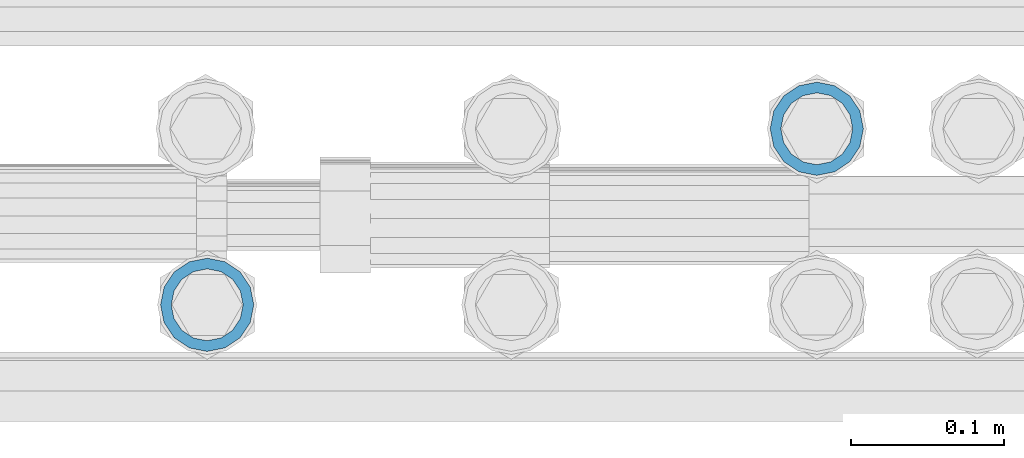
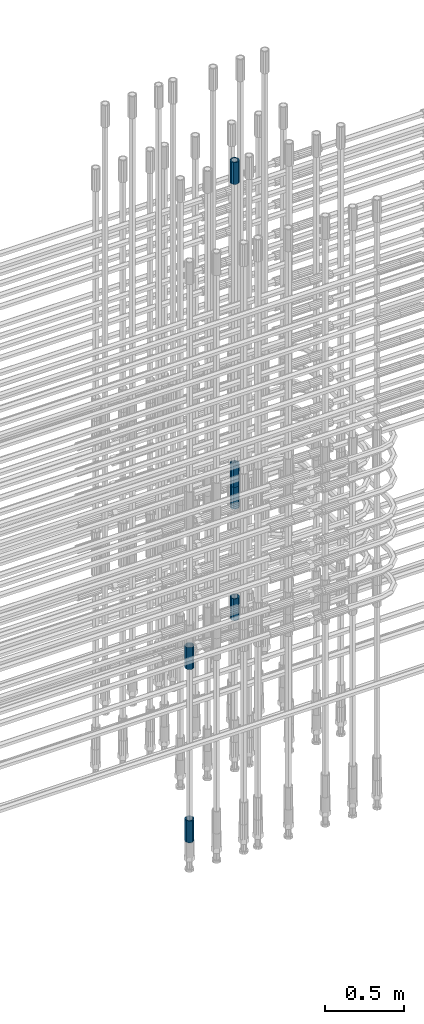
# One storey, part 19 of 119: 6 beams.
"""IFC2X3 building model written with IfcOpenShell, lengths in millimetres."""

from ifc_helpers import new_model, si_unit, frame, origin_with_axes, place, context, subcontext, project, spatial, faceted_brep, material, type_object, element, save


model = new_model("IFC2X3")

# Units and contexts
model_context = context("Model", 3, precision=1e-05, world=origin_with_axes())
body_context = subcontext(model_context, "Body", "Model", "MODEL_VIEW")
ifc_project = project(units=[si_unit("LENGTHUNIT", "METRE", prefix="MILLI"), si_unit("AREAUNIT", "SQUARE_METRE"), si_unit("VOLUMEUNIT", "CUBIC_METRE"), si_unit("MASSUNIT", "GRAM", prefix="KILO"), si_unit("TIMEUNIT", "SECOND"), si_unit("PLANEANGLEUNIT", "RADIAN"), si_unit("SOLIDANGLEUNIT", "STERADIAN"), si_unit("THERMODYNAMICTEMPERATUREUNIT", "DEGREE_CELSIUS"), si_unit("LUMINOUSINTENSITYUNIT", "LUMEN")], contexts=[model_context])

# Site, building, storey
site_placement = place(None, origin_with_axes())
site = spatial("IfcSite", under=ifc_project, at=site_placement, CompositionType="ELEMENT")
building_placement = place(site_placement, origin_with_axes())
building = spatial("IfcBuilding", under=site, at=building_placement, Name="Undefined", CompositionType="ELEMENT")
storey_placement = place(building_placement, origin_with_axes())
storey = spatial("IfcBuildingStorey", under=building, at=storey_placement, Name="Undefined", CompositionType="ELEMENT", Elevation=0.0)

# Beams
ifc_material = material(Name="STEEL/S275")
beam_type = type_object("IfcBeamType", PredefinedType="NOTDEFINED")
beam_1_placement = place(storey_placement, frame((2035525.00620663, 6205269.00125114, 20704.605729163), z_axis=(1.0, 0.0, 0.0), x_axis=(0.0, 0.0, 1.0)))
element("IfcBeam", 1, at=beam_1_placement, inside=storey, type_object=beam_type, material=ifc_material, Name="AG40N", context=body_context, shape_type="Brep", body=[
    faceted_brep([(1.62981450557709e-09, -23.4999999990687, 0.0), (7.45058059692383e-09, -21.7111690142192, 8.99306066057534), (170.000002125278, -21.711168999318, 8.99306066022245), (170.000002127141, -23.4999999844003, -3.66071617463604e-10), (4.65661287307739e-09, -16.6170093587134, 16.6170093578889), (170.000002122484, -16.6170093440451, 16.6170093575288), (1.86264514923096e-09, -8.99306066217832, 21.7111690140277), (170.000002118759, -8.99306064750999, 21.7111690136603), (2.3283064365387e-10, 9.31322574615479e-10, 23.5), (170.000002114102, 1.28056854009628e-08, 23.4999999996485), (-6.51925802230835e-09, 8.99306065868586, 21.7111690140241), (170.00000211224, 8.99306067335419, 21.7111690136639), (-7.45058059692383e-09, 16.6170093561523, 16.6170093578853), (170.000002109446, 16.6170093708206, 16.6170093575324), (-9.31322574615479e-09, 21.711169013055, 8.99306066057534), (170.000002108514, 21.7111690277234, 8.99306066022245), (-1.16415321826935e-09, 23.5000000009313, 0.0), (170.000002108514, 23.5000000144355, -3.66071617463604e-10), (-8.38190317153931e-09, 21.7111690151505, -8.99306066059444), (170.000002110377, 21.7111690300517, -8.9930606609546), (-5.58793544769287e-09, 16.6170093598776, -16.6170093579008), (170.000002113171, 16.6170093745459, -16.6170093582609), (-9.31322574615479e-10, 8.99306066334248, -21.7111690140396), (170.000002115965, 8.99306067801081, -21.7111690143961), (2.3283064365387e-10, 9.31322574615479e-10, -23.5), (170.00000211969, 1.7927959561348e-08, -23.5000000003843), (5.58793544769287e-09, -8.99306065752171, -21.7111690140396), (170.000002123415, -8.99306064285338, -21.7111690143961), (8.38190317153931e-09, -16.6170093549881, -16.6170093579008), (170.000002125278, -16.6170093403198, -16.6170093582646), (9.31322574615479e-09, -21.7111690121237, -8.99306066059444), (170.000002127141, -21.7111689972226, -8.9930606609546), (1.11758708953857e-08, -30.4999999990687, -9.54969436861575e-12), (1.30385160446167e-08, -28.1783257392235, -11.6718446871514), (170.000002129003, -28.1783257243223, -11.6718446875116), (170.000002129935, -30.4999999841675, -3.66071617463604e-10), (1.02445483207703e-08, -21.5667568228673, -21.5667568262129), (170.000002128072, -21.566756808199, -21.5667568265694), (7.45058059692383e-09, -11.6718446831219, -28.1783257416196), (170.000002125278, -11.6718446684536, -28.1783257419834), (3.72529029846191e-09, 3.95812094211578e-09, -30.5000000000277), (170.00000211969, 1.83936208486557e-08, -30.5000000003879), (-9.31322574615479e-10, 11.6718446905725, -28.1783257416232), (170.000002115965, 11.6718447052408, -28.1783257419797), (-6.51925802230835e-09, 21.5667568286881, -21.5667568262093), (170.000002110377, 21.5667568433564, -21.5667568265694), (-9.31322574615479e-09, 28.178325742716, -11.6718446871478), (170.000002108514, 28.1783257573843, -11.6718446875079), (-1.21071934700012e-08, 30.5, -5.91171556152403e-12), (170.000002106652, 30.5000000144355, -3.62433638656512e-10), (-1.21071934700012e-08, 28.1783257401548, 11.6718446871359), (170.00000210572, 28.1783257548232, 11.6718446867794), (-1.02445483207703e-08, 21.5667568240315, 21.5667568261974), (170.000002107583, 21.566756838467, 21.5667568258409), (-7.45058059692383e-09, 11.671844684286, 28.1783257416041), (170.000002110377, 11.6718446989544, 28.178325741244), (-2.79396772384644e-09, -2.56113708019257e-09, 30.5000000000159), (170.000002114102, 1.18743628263474e-08, 30.4999999996558), (1.86264514923096e-09, -11.6718446896411, 28.1783257416114), (170.000002118759, -11.67184467474, 28.178325741244), (7.45058059692383e-09, -21.5667568275239, 21.5667568261974), (170.000002123415, -21.5667568126228, 21.5667568258373), (1.02445483207703e-08, -28.1783257415518, 11.6718446871359), (170.000002127141, -28.1783257271163, 11.6718446867794)], [[[0, 1, 2, 3]], [[1, 4, 5, 2]], [[4, 6, 7, 5]], [[6, 8, 9, 7]], [[8, 10, 11, 9]], [[10, 12, 13, 11]], [[12, 14, 15, 13]], [[14, 16, 17, 15]], [[16, 18, 19, 17]], [[18, 20, 21, 19]], [[20, 22, 23, 21]], [[22, 24, 25, 23]], [[24, 26, 27, 25]], [[26, 28, 29, 27]], [[28, 30, 31, 29]], [[30, 0, 3, 31]], [[32, 33, 34, 35]], [[33, 36, 37, 34]], [[36, 38, 39, 37]], [[38, 40, 41, 39]], [[40, 42, 43, 41]], [[42, 44, 45, 43]], [[44, 46, 47, 45]], [[46, 48, 49, 47]], [[48, 50, 51, 49]], [[50, 52, 53, 51]], [[52, 54, 55, 53]], [[54, 56, 57, 55]], [[56, 58, 59, 57]], [[58, 60, 61, 59]], [[60, 62, 63, 61]], [[62, 32, 35, 63]], [[37, 39, 41, 43, 45, 47, 49, 51, 53, 55, 57, 59, 61, 63, 35, 34], [5, 7, 9, 11, 13, 15, 17, 19, 21, 23, 25, 27, 29, 31, 3, 2]], [[62, 60, 58, 56, 54, 52, 50, 48, 46, 44, 42, 40, 38, 36, 33, 32], [30, 28, 26, 24, 22, 20, 18, 16, 14, 12, 10, 8, 6, 4, 1, 0]]]),
])
beam_2_placement = place(storey_placement, frame((2035525.00620663, 6205269.00125114, 20007.7168583139), z_axis=(-0.99999999999998, 1.98000110685822e-07, 0.0), x_axis=(0.0, 0.0, -1.0)))
element("IfcBeam", 2, at=beam_2_placement, inside=storey, type_object=beam_type, material=ifc_material, Name="AG40N", context=body_context, shape_type="Brep", body=[
    faceted_brep([(1.62981450557709e-09, -23.4999999990687, 0.0), (7.45058059692383e-09, -21.7111690142192, 8.99306066057534), (170.000002125278, -21.711168999318, 8.99306066022245), (170.000002127141, -23.4999999844003, -3.66071617463604e-10), (4.65661287307739e-09, -16.6170093587134, 16.6170093578889), (170.000002122484, -16.6170093440451, 16.6170093575288), (1.86264514923096e-09, -8.99306066217832, 21.7111690140277), (170.000002118759, -8.99306064750999, 21.7111690136603), (2.3283064365387e-10, 9.31322574615479e-10, 23.5), (170.000002114102, 1.28056854009628e-08, 23.4999999996485), (-6.51925802230835e-09, 8.99306065868586, 21.7111690140241), (170.00000211224, 8.99306067335419, 21.7111690136639), (-7.45058059692383e-09, 16.6170093561523, 16.6170093578853), (170.000002109446, 16.6170093708206, 16.6170093575324), (-9.31322574615479e-09, 21.711169013055, 8.99306066057534), (170.000002108514, 21.7111690277234, 8.99306066022245), (-1.16415321826935e-09, 23.5000000009313, 0.0), (170.000002108514, 23.5000000144355, -3.66071617463604e-10), (-8.38190317153931e-09, 21.7111690151505, -8.99306066059444), (170.000002110377, 21.7111690300517, -8.9930606609546), (-5.58793544769287e-09, 16.6170093598776, -16.6170093579008), (170.000002113171, 16.6170093745459, -16.6170093582609), (-9.31322574615479e-10, 8.99306066334248, -21.7111690140396), (170.000002115965, 8.99306067801081, -21.7111690143961), (2.3283064365387e-10, 9.31322574615479e-10, -23.5), (170.00000211969, 1.7927959561348e-08, -23.5000000003843), (5.58793544769287e-09, -8.99306065752171, -21.7111690140396), (170.000002123415, -8.99306064285338, -21.7111690143961), (8.38190317153931e-09, -16.6170093549881, -16.6170093579008), (170.000002125278, -16.6170093403198, -16.6170093582646), (9.31322574615479e-09, -21.7111690121237, -8.99306066059444), (170.000002127141, -21.7111689972226, -8.9930606609546), (1.11758708953857e-08, -30.4999999990687, -9.54969436861575e-12), (1.30385160446167e-08, -28.1783257392235, -11.6718446871514), (170.000002129003, -28.1783257243223, -11.6718446875116), (170.000002129935, -30.4999999841675, -3.66071617463604e-10), (1.02445483207703e-08, -21.5667568228673, -21.5667568262129), (170.000002128072, -21.566756808199, -21.5667568265694), (7.45058059692383e-09, -11.6718446831219, -28.1783257416196), (170.000002125278, -11.6718446684536, -28.1783257419834), (3.72529029846191e-09, 3.95812094211578e-09, -30.5000000000277), (170.00000211969, 1.83936208486557e-08, -30.5000000003879), (-9.31322574615479e-10, 11.6718446905725, -28.1783257416232), (170.000002115965, 11.6718447052408, -28.1783257419797), (-6.51925802230835e-09, 21.5667568286881, -21.5667568262093), (170.000002110377, 21.5667568433564, -21.5667568265694), (-9.31322574615479e-09, 28.178325742716, -11.6718446871478), (170.000002108514, 28.1783257573843, -11.6718446875079), (-1.21071934700012e-08, 30.5, -5.91171556152403e-12), (170.000002106652, 30.5000000144355, -3.62433638656512e-10), (-1.21071934700012e-08, 28.1783257401548, 11.6718446871359), (170.00000210572, 28.1783257548232, 11.6718446867794), (-1.02445483207703e-08, 21.5667568240315, 21.5667568261974), (170.000002107583, 21.566756838467, 21.5667568258409), (-7.45058059692383e-09, 11.671844684286, 28.1783257416041), (170.000002110377, 11.6718446989544, 28.178325741244), (-2.79396772384644e-09, -2.56113708019257e-09, 30.5000000000159), (170.000002114102, 1.18743628263474e-08, 30.4999999996558), (1.86264514923096e-09, -11.6718446896411, 28.1783257416114), (170.000002118759, -11.67184467474, 28.178325741244), (7.45058059692383e-09, -21.5667568275239, 21.5667568261974), (170.000002123415, -21.5667568126228, 21.5667568258373), (1.02445483207703e-08, -28.1783257415518, 11.6718446871359), (170.000002127141, -28.1783257271163, 11.6718446867794)], [[[0, 1, 2, 3]], [[1, 4, 5, 2]], [[4, 6, 7, 5]], [[6, 8, 9, 7]], [[8, 10, 11, 9]], [[10, 12, 13, 11]], [[12, 14, 15, 13]], [[14, 16, 17, 15]], [[16, 18, 19, 17]], [[18, 20, 21, 19]], [[20, 22, 23, 21]], [[22, 24, 25, 23]], [[24, 26, 27, 25]], [[26, 28, 29, 27]], [[28, 30, 31, 29]], [[30, 0, 3, 31]], [[32, 33, 34, 35]], [[33, 36, 37, 34]], [[36, 38, 39, 37]], [[38, 40, 41, 39]], [[40, 42, 43, 41]], [[42, 44, 45, 43]], [[44, 46, 47, 45]], [[46, 48, 49, 47]], [[48, 50, 51, 49]], [[50, 52, 53, 51]], [[52, 54, 55, 53]], [[54, 56, 57, 55]], [[56, 58, 59, 57]], [[58, 60, 61, 59]], [[60, 62, 63, 61]], [[62, 32, 35, 63]], [[37, 39, 41, 43, 45, 47, 49, 51, 53, 55, 57, 59, 61, 63, 35, 34], [5, 7, 9, 11, 13, 15, 17, 19, 21, 23, 25, 27, 29, 31, 3, 2]], [[62, 60, 58, 56, 54, 52, 50, 48, 46, 44, 42, 40, 38, 36, 33, 32], [30, 28, 26, 24, 22, 20, 18, 16, 14, 12, 10, 8, 6, 4, 1, 0]]]),
])
beam_3_placement = place(storey_placement, frame((2035525.00620663, 6205269.00125114, 23229.985729163), z_axis=(1.0, 0.0, 0.0), x_axis=(0.0, 0.0, 1.0)))
element("IfcBeam", 3, at=beam_3_placement, inside=storey, type_object=beam_type, material=ifc_material, Name="AG40N", context=body_context, shape_type="Brep", body=[
    faceted_brep([(1.62981450557709e-09, -23.4999999990687, 0.0), (7.45058059692383e-09, -21.7111690142192, 8.99306066057534), (170.000002125278, -21.711168999318, 8.99306066022245), (170.000002127141, -23.4999999844003, -3.66071617463604e-10), (4.65661287307739e-09, -16.6170093587134, 16.6170093578889), (170.000002122484, -16.6170093440451, 16.6170093575288), (1.86264514923096e-09, -8.99306066217832, 21.7111690140277), (170.000002118759, -8.99306064750999, 21.7111690136603), (2.3283064365387e-10, 9.31322574615479e-10, 23.5), (170.000002114102, 1.28056854009628e-08, 23.4999999996485), (-6.51925802230835e-09, 8.99306065868586, 21.7111690140241), (170.00000211224, 8.99306067335419, 21.7111690136639), (-7.45058059692383e-09, 16.6170093561523, 16.6170093578853), (170.000002109446, 16.6170093708206, 16.6170093575324), (-9.31322574615479e-09, 21.711169013055, 8.99306066057534), (170.000002108514, 21.7111690277234, 8.99306066022245), (-1.16415321826935e-09, 23.5000000009313, 0.0), (170.000002108514, 23.5000000144355, -3.66071617463604e-10), (-8.38190317153931e-09, 21.7111690151505, -8.99306066059444), (170.000002110377, 21.7111690300517, -8.9930606609546), (-5.58793544769287e-09, 16.6170093598776, -16.6170093579008), (170.000002113171, 16.6170093745459, -16.6170093582609), (-9.31322574615479e-10, 8.99306066334248, -21.7111690140396), (170.000002115965, 8.99306067801081, -21.7111690143961), (2.3283064365387e-10, 9.31322574615479e-10, -23.5), (170.00000211969, 1.7927959561348e-08, -23.5000000003843), (5.58793544769287e-09, -8.99306065752171, -21.7111690140396), (170.000002123415, -8.99306064285338, -21.7111690143961), (8.38190317153931e-09, -16.6170093549881, -16.6170093579008), (170.000002125278, -16.6170093403198, -16.6170093582646), (9.31322574615479e-09, -21.7111690121237, -8.99306066059444), (170.000002127141, -21.7111689972226, -8.9930606609546), (1.11758708953857e-08, -30.4999999990687, -9.54969436861575e-12), (1.30385160446167e-08, -28.1783257392235, -11.6718446871514), (170.000002129003, -28.1783257243223, -11.6718446875116), (170.000002129935, -30.4999999841675, -3.66071617463604e-10), (1.02445483207703e-08, -21.5667568228673, -21.5667568262129), (170.000002128072, -21.566756808199, -21.5667568265694), (7.45058059692383e-09, -11.6718446831219, -28.1783257416196), (170.000002125278, -11.6718446684536, -28.1783257419834), (3.72529029846191e-09, 3.95812094211578e-09, -30.5000000000277), (170.00000211969, 1.83936208486557e-08, -30.5000000003879), (-9.31322574615479e-10, 11.6718446905725, -28.1783257416232), (170.000002115965, 11.6718447052408, -28.1783257419797), (-6.51925802230835e-09, 21.5667568286881, -21.5667568262093), (170.000002110377, 21.5667568433564, -21.5667568265694), (-9.31322574615479e-09, 28.178325742716, -11.6718446871478), (170.000002108514, 28.1783257573843, -11.6718446875079), (-1.21071934700012e-08, 30.5, -5.91171556152403e-12), (170.000002106652, 30.5000000144355, -3.62433638656512e-10), (-1.21071934700012e-08, 28.1783257401548, 11.6718446871359), (170.00000210572, 28.1783257548232, 11.6718446867794), (-1.02445483207703e-08, 21.5667568240315, 21.5667568261974), (170.000002107583, 21.566756838467, 21.5667568258409), (-7.45058059692383e-09, 11.671844684286, 28.1783257416041), (170.000002110377, 11.6718446989544, 28.178325741244), (-2.79396772384644e-09, -2.56113708019257e-09, 30.5000000000159), (170.000002114102, 1.18743628263474e-08, 30.4999999996558), (1.86264514923096e-09, -11.6718446896411, 28.1783257416114), (170.000002118759, -11.67184467474, 28.178325741244), (7.45058059692383e-09, -21.5667568275239, 21.5667568261974), (170.000002123415, -21.5667568126228, 21.5667568258373), (1.02445483207703e-08, -28.1783257415518, 11.6718446871359), (170.000002127141, -28.1783257271163, 11.6718446867794)], [[[0, 1, 2, 3]], [[1, 4, 5, 2]], [[4, 6, 7, 5]], [[6, 8, 9, 7]], [[8, 10, 11, 9]], [[10, 12, 13, 11]], [[12, 14, 15, 13]], [[14, 16, 17, 15]], [[16, 18, 19, 17]], [[18, 20, 21, 19]], [[20, 22, 23, 21]], [[22, 24, 25, 23]], [[24, 26, 27, 25]], [[26, 28, 29, 27]], [[28, 30, 31, 29]], [[30, 0, 3, 31]], [[32, 33, 34, 35]], [[33, 36, 37, 34]], [[36, 38, 39, 37]], [[38, 40, 41, 39]], [[40, 42, 43, 41]], [[42, 44, 45, 43]], [[44, 46, 47, 45]], [[46, 48, 49, 47]], [[48, 50, 51, 49]], [[50, 52, 53, 51]], [[52, 54, 55, 53]], [[54, 56, 57, 55]], [[56, 58, 59, 57]], [[58, 60, 61, 59]], [[60, 62, 63, 61]], [[62, 32, 35, 63]], [[37, 39, 41, 43, 45, 47, 49, 51, 53, 55, 57, 59, 61, 63, 35, 34], [5, 7, 9, 11, 13, 15, 17, 19, 21, 23, 25, 27, 29, 31, 3, 2]], [[62, 60, 58, 56, 54, 52, 50, 48, 46, 44, 42, 40, 38, 36, 33, 32], [30, 28, 26, 24, 22, 20, 18, 16, 14, 12, 10, 8, 6, 4, 1, 0]]]),
])
beam_4_placement = place(storey_placement, frame((2035525.00620663, 6205269.00125114, 21044.6068583132), z_axis=(-0.99999999999998, 1.98000110685822e-07, 0.0), x_axis=(0.0, 0.0, -1.0)))
element("IfcBeam", 4, at=beam_4_placement, inside=storey, type_object=beam_type, material=ifc_material, Name="AG40N", context=body_context, shape_type="Brep", body=[
    faceted_brep([(1.62981450557709e-09, -23.4999999990687, 0.0), (7.45058059692383e-09, -21.7111690142192, 8.99306066057534), (170.000002125278, -21.711168999318, 8.99306066022245), (170.000002127141, -23.4999999844003, -3.66071617463604e-10), (4.65661287307739e-09, -16.6170093587134, 16.6170093578889), (170.000002122484, -16.6170093440451, 16.6170093575288), (1.86264514923096e-09, -8.99306066217832, 21.7111690140277), (170.000002118759, -8.99306064750999, 21.7111690136603), (2.3283064365387e-10, 9.31322574615479e-10, 23.5), (170.000002114102, 1.28056854009628e-08, 23.4999999996485), (-6.51925802230835e-09, 8.99306065868586, 21.7111690140241), (170.00000211224, 8.99306067335419, 21.7111690136639), (-7.45058059692383e-09, 16.6170093561523, 16.6170093578853), (170.000002109446, 16.6170093708206, 16.6170093575324), (-9.31322574615479e-09, 21.711169013055, 8.99306066057534), (170.000002108514, 21.7111690277234, 8.99306066022245), (-1.16415321826935e-09, 23.5000000009313, 0.0), (170.000002108514, 23.5000000144355, -3.66071617463604e-10), (-8.38190317153931e-09, 21.7111690151505, -8.99306066059444), (170.000002110377, 21.7111690300517, -8.9930606609546), (-5.58793544769287e-09, 16.6170093598776, -16.6170093579008), (170.000002113171, 16.6170093745459, -16.6170093582609), (-9.31322574615479e-10, 8.99306066334248, -21.7111690140396), (170.000002115965, 8.99306067801081, -21.7111690143961), (2.3283064365387e-10, 9.31322574615479e-10, -23.5), (170.00000211969, 1.7927959561348e-08, -23.5000000003843), (5.58793544769287e-09, -8.99306065752171, -21.7111690140396), (170.000002123415, -8.99306064285338, -21.7111690143961), (8.38190317153931e-09, -16.6170093549881, -16.6170093579008), (170.000002125278, -16.6170093403198, -16.6170093582646), (9.31322574615479e-09, -21.7111690121237, -8.99306066059444), (170.000002127141, -21.7111689972226, -8.9930606609546), (1.11758708953857e-08, -30.4999999990687, -9.54969436861575e-12), (1.30385160446167e-08, -28.1783257392235, -11.6718446871514), (170.000002129003, -28.1783257243223, -11.6718446875116), (170.000002129935, -30.4999999841675, -3.66071617463604e-10), (1.02445483207703e-08, -21.5667568228673, -21.5667568262129), (170.000002128072, -21.566756808199, -21.5667568265694), (7.45058059692383e-09, -11.6718446831219, -28.1783257416196), (170.000002125278, -11.6718446684536, -28.1783257419834), (3.72529029846191e-09, 3.95812094211578e-09, -30.5000000000277), (170.00000211969, 1.83936208486557e-08, -30.5000000003879), (-9.31322574615479e-10, 11.6718446905725, -28.1783257416232), (170.000002115965, 11.6718447052408, -28.1783257419797), (-6.51925802230835e-09, 21.5667568286881, -21.5667568262093), (170.000002110377, 21.5667568433564, -21.5667568265694), (-9.31322574615479e-09, 28.178325742716, -11.6718446871478), (170.000002108514, 28.1783257573843, -11.6718446875079), (-1.21071934700012e-08, 30.5, -5.91171556152403e-12), (170.000002106652, 30.5000000144355, -3.62433638656512e-10), (-1.21071934700012e-08, 28.1783257401548, 11.6718446871359), (170.00000210572, 28.1783257548232, 11.6718446867794), (-1.02445483207703e-08, 21.5667568240315, 21.5667568261974), (170.000002107583, 21.566756838467, 21.5667568258409), (-7.45058059692383e-09, 11.671844684286, 28.1783257416041), (170.000002110377, 11.6718446989544, 28.178325741244), (-2.79396772384644e-09, -2.56113708019257e-09, 30.5000000000159), (170.000002114102, 1.18743628263474e-08, 30.4999999996558), (1.86264514923096e-09, -11.6718446896411, 28.1783257416114), (170.000002118759, -11.67184467474, 28.178325741244), (7.45058059692383e-09, -21.5667568275239, 21.5667568261974), (170.000002123415, -21.5667568126228, 21.5667568258373), (1.02445483207703e-08, -28.1783257415518, 11.6718446871359), (170.000002127141, -28.1783257271163, 11.6718446867794)], [[[0, 1, 2, 3]], [[1, 4, 5, 2]], [[4, 6, 7, 5]], [[6, 8, 9, 7]], [[8, 10, 11, 9]], [[10, 12, 13, 11]], [[12, 14, 15, 13]], [[14, 16, 17, 15]], [[16, 18, 19, 17]], [[18, 20, 21, 19]], [[20, 22, 23, 21]], [[22, 24, 25, 23]], [[24, 26, 27, 25]], [[26, 28, 29, 27]], [[28, 30, 31, 29]], [[30, 0, 3, 31]], [[32, 33, 34, 35]], [[33, 36, 37, 34]], [[36, 38, 39, 37]], [[38, 40, 41, 39]], [[40, 42, 43, 41]], [[42, 44, 45, 43]], [[44, 46, 47, 45]], [[46, 48, 49, 47]], [[48, 50, 51, 49]], [[50, 52, 53, 51]], [[52, 54, 55, 53]], [[54, 56, 57, 55]], [[56, 58, 59, 57]], [[58, 60, 61, 59]], [[60, 62, 63, 61]], [[62, 32, 35, 63]], [[37, 39, 41, 43, 45, 47, 49, 51, 53, 55, 57, 59, 61, 63, 35, 34], [5, 7, 9, 11, 13, 15, 17, 19, 21, 23, 25, 27, 29, 31, 3, 2]], [[62, 60, 58, 56, 54, 52, 50, 48, 46, 44, 42, 40, 38, 36, 33, 32], [30, 28, 26, 24, 22, 20, 18, 16, 14, 12, 10, 8, 6, 4, 1, 0]]]),
])
beam_5_placement = place(storey_placement, frame((2035126.00651562, 6205153.77086634, 19667.7157291644), z_axis=(1.0, 0.0, 0.0), x_axis=(0.0, 0.0, 1.0)))
element("IfcBeam", 5, at=beam_5_placement, inside=storey, type_object=beam_type, material=ifc_material, Name="AG40N", context=body_context, shape_type="Brep", body=[
    faceted_brep([(1.62981450557709e-09, -23.4999999990687, 0.0), (7.45058059692383e-09, -21.7111690142192, 8.99306066057534), (170.000002125278, -21.711168999318, 8.99306066022245), (170.000002127141, -23.4999999844003, -3.66071617463604e-10), (4.65661287307739e-09, -16.6170093587134, 16.6170093578889), (170.000002122484, -16.6170093440451, 16.6170093575288), (1.86264514923096e-09, -8.99306066217832, 21.7111690140277), (170.000002118759, -8.99306064750999, 21.7111690136603), (2.3283064365387e-10, 9.31322574615479e-10, 23.5), (170.000002114102, 1.28056854009628e-08, 23.4999999996485), (-6.51925802230835e-09, 8.99306065868586, 21.7111690140241), (170.00000211224, 8.99306067335419, 21.7111690136639), (-7.45058059692383e-09, 16.6170093561523, 16.6170093578853), (170.000002109446, 16.6170093708206, 16.6170093575324), (-9.31322574615479e-09, 21.711169013055, 8.99306066057534), (170.000002108514, 21.7111690277234, 8.99306066022245), (-1.16415321826935e-09, 23.5000000009313, 0.0), (170.000002108514, 23.5000000144355, -3.66071617463604e-10), (-8.38190317153931e-09, 21.7111690151505, -8.99306066059444), (170.000002110377, 21.7111690300517, -8.9930606609546), (-5.58793544769287e-09, 16.6170093598776, -16.6170093579008), (170.000002113171, 16.6170093745459, -16.6170093582609), (-9.31322574615479e-10, 8.99306066334248, -21.7111690140396), (170.000002115965, 8.99306067801081, -21.7111690143961), (2.3283064365387e-10, 9.31322574615479e-10, -23.5), (170.00000211969, 1.7927959561348e-08, -23.5000000003843), (5.58793544769287e-09, -8.99306065752171, -21.7111690140396), (170.000002123415, -8.99306064285338, -21.7111690143961), (8.38190317153931e-09, -16.6170093549881, -16.6170093579008), (170.000002125278, -16.6170093403198, -16.6170093582646), (9.31322574615479e-09, -21.7111690121237, -8.99306066059444), (170.000002127141, -21.7111689972226, -8.9930606609546), (1.11758708953857e-08, -30.4999999990687, -9.54969436861575e-12), (1.30385160446167e-08, -28.1783257392235, -11.6718446871514), (170.000002129003, -28.1783257243223, -11.6718446875116), (170.000002129935, -30.4999999841675, -3.66071617463604e-10), (1.02445483207703e-08, -21.5667568228673, -21.5667568262129), (170.000002128072, -21.566756808199, -21.5667568265694), (7.45058059692383e-09, -11.6718446831219, -28.1783257416196), (170.000002125278, -11.6718446684536, -28.1783257419834), (3.72529029846191e-09, 3.95812094211578e-09, -30.5000000000277), (170.00000211969, 1.83936208486557e-08, -30.5000000003879), (-9.31322574615479e-10, 11.6718446905725, -28.1783257416232), (170.000002115965, 11.6718447052408, -28.1783257419797), (-6.51925802230835e-09, 21.5667568286881, -21.5667568262093), (170.000002110377, 21.5667568433564, -21.5667568265694), (-9.31322574615479e-09, 28.178325742716, -11.6718446871478), (170.000002108514, 28.1783257573843, -11.6718446875079), (-1.21071934700012e-08, 30.5, -5.91171556152403e-12), (170.000002106652, 30.5000000144355, -3.62433638656512e-10), (-1.21071934700012e-08, 28.1783257401548, 11.6718446871359), (170.00000210572, 28.1783257548232, 11.6718446867794), (-1.02445483207703e-08, 21.5667568240315, 21.5667568261974), (170.000002107583, 21.566756838467, 21.5667568258409), (-7.45058059692383e-09, 11.671844684286, 28.1783257416041), (170.000002110377, 11.6718446989544, 28.178325741244), (-2.79396772384644e-09, -2.56113708019257e-09, 30.5000000000159), (170.000002114102, 1.18743628263474e-08, 30.4999999996558), (1.86264514923096e-09, -11.6718446896411, 28.1783257416114), (170.000002118759, -11.67184467474, 28.178325741244), (7.45058059692383e-09, -21.5667568275239, 21.5667568261974), (170.000002123415, -21.5667568126228, 21.5667568258373), (1.02445483207703e-08, -28.1783257415518, 11.6718446871359), (170.000002127141, -28.1783257271163, 11.6718446867794)], [[[0, 1, 2, 3]], [[1, 4, 5, 2]], [[4, 6, 7, 5]], [[6, 8, 9, 7]], [[8, 10, 11, 9]], [[10, 12, 13, 11]], [[12, 14, 15, 13]], [[14, 16, 17, 15]], [[16, 18, 19, 17]], [[18, 20, 21, 19]], [[20, 22, 23, 21]], [[22, 24, 25, 23]], [[24, 26, 27, 25]], [[26, 28, 29, 27]], [[28, 30, 31, 29]], [[30, 0, 3, 31]], [[32, 33, 34, 35]], [[33, 36, 37, 34]], [[36, 38, 39, 37]], [[38, 40, 41, 39]], [[40, 42, 43, 41]], [[42, 44, 45, 43]], [[44, 46, 47, 45]], [[46, 48, 49, 47]], [[48, 50, 51, 49]], [[50, 52, 53, 51]], [[52, 54, 55, 53]], [[54, 56, 57, 55]], [[56, 58, 59, 57]], [[58, 60, 61, 59]], [[60, 62, 63, 61]], [[62, 32, 35, 63]], [[37, 39, 41, 43, 45, 47, 49, 51, 53, 55, 57, 59, 61, 63, 35, 34], [5, 7, 9, 11, 13, 15, 17, 19, 21, 23, 25, 27, 29, 31, 3, 2]], [[62, 60, 58, 56, 54, 52, 50, 48, 46, 44, 42, 40, 38, 36, 33, 32], [30, 28, 26, 24, 22, 20, 18, 16, 14, 12, 10, 8, 6, 4, 1, 0]]]),
])
beam_6_placement = place(storey_placement, frame((2035126.00651562, 6205153.77086634, 18490.9668583153), z_axis=(-0.99999999999998, 1.98000110685822e-07, 0.0), x_axis=(0.0, 0.0, -1.0)))
element("IfcBeam", 6, at=beam_6_placement, inside=storey, type_object=beam_type, material=ifc_material, Name="AG40N", context=body_context, shape_type="Brep", body=[
    faceted_brep([(1.62981450557709e-09, -23.4999999990687, 0.0), (7.45058059692383e-09, -21.7111690142192, 8.99306066057534), (170.000002125278, -21.711168999318, 8.99306066022245), (170.000002127141, -23.4999999844003, -3.66071617463604e-10), (4.65661287307739e-09, -16.6170093587134, 16.6170093578889), (170.000002122484, -16.6170093440451, 16.6170093575288), (1.86264514923096e-09, -8.99306066217832, 21.7111690140277), (170.000002118759, -8.99306064750999, 21.7111690136603), (2.3283064365387e-10, 9.31322574615479e-10, 23.5), (170.000002114102, 1.28056854009628e-08, 23.4999999996485), (-6.51925802230835e-09, 8.99306065868586, 21.7111690140241), (170.00000211224, 8.99306067335419, 21.7111690136639), (-7.45058059692383e-09, 16.6170093561523, 16.6170093578853), (170.000002109446, 16.6170093708206, 16.6170093575324), (-9.31322574615479e-09, 21.711169013055, 8.99306066057534), (170.000002108514, 21.7111690277234, 8.99306066022245), (-1.16415321826935e-09, 23.5000000009313, 0.0), (170.000002108514, 23.5000000144355, -3.66071617463604e-10), (-8.38190317153931e-09, 21.7111690151505, -8.99306066059444), (170.000002110377, 21.7111690300517, -8.9930606609546), (-5.58793544769287e-09, 16.6170093598776, -16.6170093579008), (170.000002113171, 16.6170093745459, -16.6170093582609), (-9.31322574615479e-10, 8.99306066334248, -21.7111690140396), (170.000002115965, 8.99306067801081, -21.7111690143961), (2.3283064365387e-10, 9.31322574615479e-10, -23.5), (170.00000211969, 1.7927959561348e-08, -23.5000000003843), (5.58793544769287e-09, -8.99306065752171, -21.7111690140396), (170.000002123415, -8.99306064285338, -21.7111690143961), (8.38190317153931e-09, -16.6170093549881, -16.6170093579008), (170.000002125278, -16.6170093403198, -16.6170093582646), (9.31322574615479e-09, -21.7111690121237, -8.99306066059444), (170.000002127141, -21.7111689972226, -8.9930606609546), (1.11758708953857e-08, -30.4999999990687, -9.54969436861575e-12), (1.30385160446167e-08, -28.1783257392235, -11.6718446871514), (170.000002129003, -28.1783257243223, -11.6718446875116), (170.000002129935, -30.4999999841675, -3.66071617463604e-10), (1.02445483207703e-08, -21.5667568228673, -21.5667568262129), (170.000002128072, -21.566756808199, -21.5667568265694), (7.45058059692383e-09, -11.6718446831219, -28.1783257416196), (170.000002125278, -11.6718446684536, -28.1783257419834), (3.72529029846191e-09, 3.95812094211578e-09, -30.5000000000277), (170.00000211969, 1.83936208486557e-08, -30.5000000003879), (-9.31322574615479e-10, 11.6718446905725, -28.1783257416232), (170.000002115965, 11.6718447052408, -28.1783257419797), (-6.51925802230835e-09, 21.5667568286881, -21.5667568262093), (170.000002110377, 21.5667568433564, -21.5667568265694), (-9.31322574615479e-09, 28.178325742716, -11.6718446871478), (170.000002108514, 28.1783257573843, -11.6718446875079), (-1.21071934700012e-08, 30.5, -5.91171556152403e-12), (170.000002106652, 30.5000000144355, -3.62433638656512e-10), (-1.21071934700012e-08, 28.1783257401548, 11.6718446871359), (170.00000210572, 28.1783257548232, 11.6718446867794), (-1.02445483207703e-08, 21.5667568240315, 21.5667568261974), (170.000002107583, 21.566756838467, 21.5667568258409), (-7.45058059692383e-09, 11.671844684286, 28.1783257416041), (170.000002110377, 11.6718446989544, 28.178325741244), (-2.79396772384644e-09, -2.56113708019257e-09, 30.5000000000159), (170.000002114102, 1.18743628263474e-08, 30.4999999996558), (1.86264514923096e-09, -11.6718446896411, 28.1783257416114), (170.000002118759, -11.67184467474, 28.178325741244), (7.45058059692383e-09, -21.5667568275239, 21.5667568261974), (170.000002123415, -21.5667568126228, 21.5667568258373), (1.02445483207703e-08, -28.1783257415518, 11.6718446871359), (170.000002127141, -28.1783257271163, 11.6718446867794)], [[[0, 1, 2, 3]], [[1, 4, 5, 2]], [[4, 6, 7, 5]], [[6, 8, 9, 7]], [[8, 10, 11, 9]], [[10, 12, 13, 11]], [[12, 14, 15, 13]], [[14, 16, 17, 15]], [[16, 18, 19, 17]], [[18, 20, 21, 19]], [[20, 22, 23, 21]], [[22, 24, 25, 23]], [[24, 26, 27, 25]], [[26, 28, 29, 27]], [[28, 30, 31, 29]], [[30, 0, 3, 31]], [[32, 33, 34, 35]], [[33, 36, 37, 34]], [[36, 38, 39, 37]], [[38, 40, 41, 39]], [[40, 42, 43, 41]], [[42, 44, 45, 43]], [[44, 46, 47, 45]], [[46, 48, 49, 47]], [[48, 50, 51, 49]], [[50, 52, 53, 51]], [[52, 54, 55, 53]], [[54, 56, 57, 55]], [[56, 58, 59, 57]], [[58, 60, 61, 59]], [[60, 62, 63, 61]], [[62, 32, 35, 63]], [[37, 39, 41, 43, 45, 47, 49, 51, 53, 55, 57, 59, 61, 63, 35, 34], [5, 7, 9, 11, 13, 15, 17, 19, 21, 23, 25, 27, 29, 31, 3, 2]], [[62, 60, 58, 56, 54, 52, 50, 48, 46, 44, 42, 40, 38, 36, 33, 32], [30, 28, 26, 24, 22, 20, 18, 16, 14, 12, 10, 8, 6, 4, 1, 0]]]),
])

save(model, "model.ifc")
